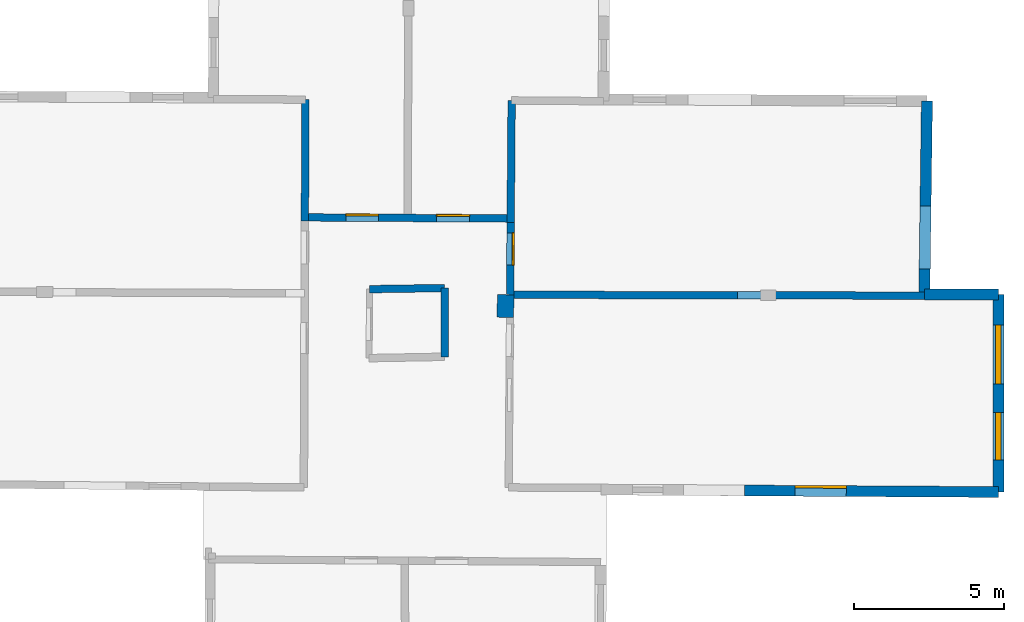
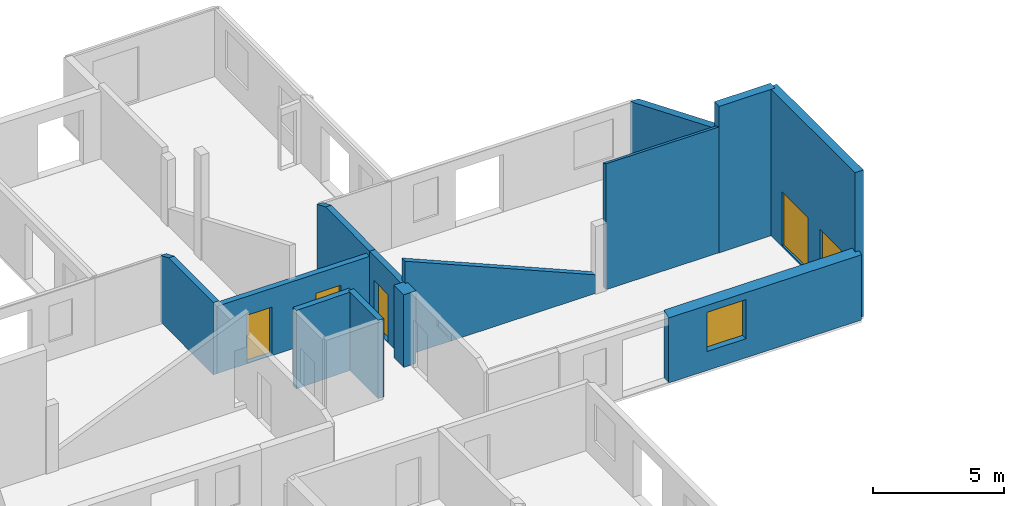
# One storey, part 7 of 10: 13 walls, 4 doors, 2 windows, 7 openings.
"""IFC2X3 building model written with IfcOpenShell, lengths in metres."""

from ifc_helpers import new_model, entity, si_unit, converted_unit, derived_unit, direction, frame, frame_2d, origin, origin_2d_with_axis, place, context, subcontext, project, spatial, polyline, rectangle, outline, extrude, clip, halfspace, source, transform, mapped, material, layer, layer_set, layer_usage, type_object, type_shapes, element, fill, save


model = new_model("IFC2X3")

# Units and contexts
model_context = context("Model", 3, precision=1e-05, world=origin(), true_north=direction((0.0, 1.0)))
body_context = subcontext(model_context, "Body", "Model", "MODEL_VIEW")
ifc_project = project(units=[si_unit("LENGTHUNIT", "METRE"), si_unit("AREAUNIT", "SQUARE_METRE"), si_unit("VOLUMEUNIT", "CUBIC_METRE"), converted_unit("PLANEANGLEUNIT", "DEGREE", entity("IfcRatioMeasure", 0.0174532925199433), si_unit("PLANEANGLEUNIT", "RADIAN"), dimensions=[0, 0, 0, 0, 0, 0, 0]), si_unit("MASSUNIT", "GRAM", prefix="KILO"), derived_unit("MASSDENSITYUNIT", [(si_unit("MASSUNIT", "GRAM", prefix="KILO"), 1), (si_unit("LENGTHUNIT", "METRE"), -3)]), derived_unit("MOMENTOFINERTIAUNIT", [(si_unit("LENGTHUNIT", "METRE"), 4)]), si_unit("TIMEUNIT", "SECOND"), si_unit("FREQUENCYUNIT", "HERTZ"), si_unit("THERMODYNAMICTEMPERATUREUNIT", "DEGREE_CELSIUS"), derived_unit("THERMALTRANSMITTANCEUNIT", [(si_unit("MASSUNIT", "GRAM", prefix="KILO"), 1), (si_unit("THERMODYNAMICTEMPERATUREUNIT", "KELVIN"), -1), (si_unit("TIMEUNIT", "SECOND"), -3)]), derived_unit("VOLUMETRICFLOWRATEUNIT", [(si_unit("LENGTHUNIT", "METRE"), 3), (si_unit("TIMEUNIT", "SECOND"), -1)]), si_unit("ELECTRICCURRENTUNIT", "AMPERE"), si_unit("ELECTRICVOLTAGEUNIT", "VOLT"), si_unit("POWERUNIT", "WATT"), si_unit("FORCEUNIT", "NEWTON", prefix="KILO"), si_unit("ILLUMINANCEUNIT", "LUX"), si_unit("LUMINOUSFLUXUNIT", "LUMEN"), si_unit("LUMINOUSINTENSITYUNIT", "CANDELA"), derived_unit("USERDEFINED", [(si_unit("MASSUNIT", "GRAM", prefix="KILO"), -1), (si_unit("LENGTHUNIT", "METRE"), -2), (si_unit("TIMEUNIT", "SECOND"), 3), (si_unit("LUMINOUSFLUXUNIT", "LUMEN"), 1)]), derived_unit("LINEARVELOCITYUNIT", [(si_unit("LENGTHUNIT", "METRE"), 1), (si_unit("TIMEUNIT", "SECOND"), -1)]), si_unit("PRESSUREUNIT", "PASCAL"), derived_unit("USERDEFINED", [(si_unit("LENGTHUNIT", "METRE"), -2), (si_unit("MASSUNIT", "GRAM", prefix="KILO"), 1), (si_unit("TIMEUNIT", "SECOND"), -2)]), derived_unit("LINEARFORCEUNIT", [(si_unit("MASSUNIT", "GRAM", prefix="KILO"), 1), (si_unit("LENGTHUNIT", "METRE"), 1), (si_unit("TIMEUNIT", "SECOND"), -2), (si_unit("LENGTHUNIT", "METRE"), -1)]), derived_unit("PLANARFORCEUNIT", [(si_unit("MASSUNIT", "GRAM", prefix="KILO"), 1), (si_unit("LENGTHUNIT", "METRE"), 1), (si_unit("TIMEUNIT", "SECOND"), -2), (si_unit("LENGTHUNIT", "METRE"), -2)])], contexts=[model_context])

# Site, building, storey
placement = place(None, origin())
site = spatial("IfcSite", under=ifc_project, at=placement, CompositionType="ELEMENT")
building = spatial("IfcBuilding", under=site, at=placement, CompositionType="ELEMENT")
storey_placement = place(placement, frame((0.0, 0.0, 15.2695512771606)))
storey = spatial("IfcBuildingStorey", under=building, at=storey_placement, Name="Level 6", CompositionType="ELEMENT", Elevation=15.2695512771606)

# Wall, openings, doors
ifc_material_1 = material(Name="Default wall")
ifc_layer_1 = layer(ifc_material_1, 0.25)
ifc_layer_set_1 = layer_set([ifc_layer_1], Name="wall_thickness_0.2500")
ifc_layer_usage_1 = layer_usage(ifc_layer_set_1, "AXIS2", "POSITIVE", -0.125)
wall_type_1 = type_object("IfcWallType", Name="wall_thickness_0.2500", PredefinedType="STANDARD", material=ifc_layer_set_1)
wall_1_placement = place(storey_placement, frame((2.96713424520515, 60.1743794273045, 0.0), z_axis=(0.0, 0.0, 1.0), x_axis=(0.999985370043432, -0.00540922352097356, 0.0)))
wall_1 = element("IfcWallStandardCase", 1, at=wall_1_placement, inside=storey, type_object=wall_type_1, material=ifc_layer_usage_1, Name="Wall:130", ObjectType="Wall", context=body_context, shape_type="Clipping", body=[
    clip(clip(extrude(outline(polyline([(6.8448736711646, -0.125), (6.8448736711646, 0.125), (0.0, 0.125), (0.0, -0.125), (6.8448736711646, -0.125)])), origin(), (0.0, 0.0, 1.0), 3.13044834136963), halfspace(frame((21.6737388787584, -2.55460759701524, 5.8221630359936), z_axis=(0.000366542898802136, 0.389455013607563, 0.921045415830423), x_axis=(-0.999995954296972, 0.00274085757237607, -0.000760979274747706)), False)), halfspace(frame((9.75695270182333, 17.1152665483417, 3.16730048752112), z_axis=(0.390500067069403, 0.000208506375133906, 0.920602875372374), x_axis=(-0.680068275737413, -0.67394641392533, 0.288623234499112)), False)),
])
opening_1_placement = place(wall_1_placement, frame((1.36070263379295, -0.125, 0.0334491729736328)))
opening_1 = element("IfcOpeningElement", 2, at=opening_1_placement, cuts=wall_1, Name="Opening : 1085 x 2225 : 119", ObjectType="Opening", context=body_context, shape_type="SweptSolid", body=[
    extrude(rectangle(XDim=1.085, YDim=2.225, at=frame_2d((1.1125, 0.5425), x_axis=(0.0, 1.0))), frame((0.0, 0.0, 0.0), z_axis=(0.0, 1.0, 0.0), x_axis=(0.0, 0.0, 1.0)), (0.0, 0.0, 1.0), 0.25),
])
opening_2_placement = place(wall_1_placement, frame((4.37401757615406, -0.125, 0.00844955444335938)))
opening_2 = element("IfcOpeningElement", 3, at=opening_2_placement, cuts=wall_1, Name="Opening : 1105 x 2220 : 120", ObjectType="Opening", context=body_context, shape_type="SweptSolid", body=[
    extrude(rectangle(XDim=1.105, YDim=2.22, at=frame_2d((1.11, 0.5525), x_axis=(0.0, 1.0))), frame((0.0, 0.0, 0.0), z_axis=(0.0, 1.0, 0.0), x_axis=(0.0, 0.0, 1.0)), (0.0, 0.0, 1.0), 0.25),
])
ifc_material_2 = material(Name="Door Panel")
door_style_1 = type_object("IfcDoorStyle", Name="Door : 1085 x 2225mm", ConstructionType="NOTDEFINED", OperationType="SINGLE_SWING_RIGHT", ParameterTakesPrecedence=False, Sizeable=False, material=ifc_material_2)
shared_shape_1 = source(origin(), body_context, "Body", "SweptSolid", [
    extrude(rectangle(XDim=0.0625, YDim=1.085, at=origin_2d_with_axis()), frame((0.5425, 0.21875, 0.0), z_axis=(0.0, 0.0, 1.0), x_axis=(0.0, 1.0, 0.0)), (0.0, 0.0, 1.0), 2.225),
])
type_shapes(door_style_1, [shared_shape_1])
door_1_placement = place(opening_1_placement, origin())
door_1 = element("IfcDoor", 4, at=door_1_placement, inside=storey, type_object=door_style_1, Name="Door : 1085 x 2225mm : 18", ObjectType="Door : 1085 x 2225mm", OverallHeight=2.225, OverallWidth=1.085, context=body_context, shape_type="MappedRepresentation", body=[
    mapped(shared_shape_1, transform((0.0, 0.0, 0.0), scale=1.0)),
])
fill(opening_1, door_1)
door_style_2 = type_object("IfcDoorStyle", Name="Door : 1105 x 2220mm", ConstructionType="NOTDEFINED", OperationType="SINGLE_SWING_RIGHT", ParameterTakesPrecedence=False, Sizeable=False, material=ifc_material_2)
shared_shape_2 = source(origin(), body_context, "Body", "SweptSolid", [
    extrude(rectangle(XDim=0.0625, YDim=1.105, at=origin_2d_with_axis()), frame((0.5525, 0.21875, 0.0), z_axis=(0.0, 0.0, 1.0), x_axis=(0.0, 1.0, 0.0)), (0.0, 0.0, 1.0), 2.22),
])
type_shapes(door_style_2, [shared_shape_2])
door_2_placement = place(opening_2_placement, origin())
door_2 = element("IfcDoor", 5, at=door_2_placement, inside=storey, type_object=door_style_2, Name="Door : 1105 x 2220mm : 19", ObjectType="Door : 1105 x 2220mm", OverallHeight=2.22, OverallWidth=1.105, context=body_context, shape_type="MappedRepresentation", body=[
    mapped(shared_shape_2, transform((0.0, 0.0, 0.0), scale=1.0)),
])
fill(opening_2, door_2)

# Walls
wall_2_placement = place(storey_placement, frame((7.61093044283214, 57.8249602665871, 0.0), z_axis=(0.0, 0.0, 1.0), x_axis=(1.87735608155193e-05, -0.999999999823777, 0.0)))
element("IfcWallStandardCase", 6, at=wall_2_placement, inside=storey, type_object=wall_type_1, material=ifc_layer_usage_1, Name="Wall:150", ObjectType="Wall", context=body_context, shape_type="Clipping", body=[
    clip(clip(extrude(outline(polyline([(2.28594589273682, -0.125), (2.28594589273682, 0.125), (0.0, 0.125), (0.0, -0.125), (2.28594589273682, -0.125)])), origin(), (0.0, 0.0, 1.0), 3.64244747161865), halfspace(frame((0.0173498715267402, -20.3641007855674, 5.82614615592769), z_axis=(0.391110357303732, -0.00389535867308116, 0.920335544565435), x_axis=(0.00816873617874139, 0.999966345768865, 0.00076097234127326)), False)), halfspace(frame((-19.4115600444475, 5.20595848780353, 3.16730048752112), z_axis=(0.00191112981338156, 0.390495446118074, 0.920602875372374), x_axis=(0.670245077131597, -0.68371643616936, 0.288623234499112)), False)),
])
wall_3_placement = place(storey_placement, frame((18.6168514417804, 57.5909596654291, 0.0), z_axis=(0.0, 0.0, 1.0), x_axis=(0.999985671317579, -0.0053532382284126, 0.0)))
element("IfcWallStandardCase", 7, at=wall_3_placement, inside=storey, type_object=wall_type_1, material=ifc_layer_usage_1, Name="Wall:160", ObjectType="Wall", context=body_context, shape_type="Clipping", body=[
    clip(extrude(outline(polyline([(4.95254365019272, -0.125), (4.95254365019272, 0.125), (0.0, 0.125), (0.0, -0.125), (4.95254365019272, -0.125)])), origin(), (0.0, 0.0, 1.0), 6.0254487991333), halfspace(frame((6.01027320408955, -0.0562149406787543, 5.8221630359936), z_axis=(0.000388346966794823, 0.389454992475892, 0.921045415830423), x_axis=(-0.999995799279822, 0.00279684344473516, -0.000760979274747706)), False)),
])
wall_4_placement = place(storey_placement, frame((9.79176478291498, 57.6015514875423, 0.0), z_axis=(0.0, 0.0, 1.0), x_axis=(0.999996547055359, -0.00262790360528779, 0.0)))
element("IfcWallStandardCase", 8, at=wall_4_placement, inside=storey, type_object=wall_type_1, material=ifc_layer_usage_1, Name="Wall:165", ObjectType="Wall", context=body_context, shape_type="Clipping", body=[
    clip(clip(extrude(outline(polyline([(8.35402893755218, -0.125), (8.35402893755218, 0.125), (0.0, 0.125), (0.0, -0.125), (8.35402893755218, -0.125)])), origin(), (0.0, 0.0, 1.0), 4.78644847869873), halfspace(frame((14.8351816982513, -0.0599951612753503, 5.8221630359936), z_axis=(0.00144974816553861, 0.38945248774147, 0.921045415830423), x_axis=(-0.999984463123986, 0.00552217540250109, -0.000760979274747706)), False)), halfspace(frame((2.97315021618388, 19.6429475326324, 3.16730048752112), z_axis=(0.39049913656848, -0.000877607764519829, 0.920602875372374), x_axis=(-0.681940119185066, -0.672052306262785, 0.288623234499112)), False)),
])
wall_5_placement = place(storey_placement, frame((9.84309972223119, 64.0643778277319, 0.0), z_axis=(0.0, 0.0, 1.0), x_axis=(-0.00794283618112411, -0.999968455179162, 0.0)))
element("IfcWallStandardCase", 9, at=wall_5_placement, inside=storey, type_object=wall_type_1, material=ifc_layer_usage_1, Name="Wall:195", ObjectType="Wall", context=body_context, shape_type="Clipping", body=[
    clip(clip(extrude(outline(polyline([(4.05214885092084, -0.125), (4.05214885092084, 0.125), (0.0, 0.125), (0.0, -0.125), (4.05214885092084, -0.125)])), origin(), (0.0, 0.0, 1.0), 3.37544918060303), halfspace(frame((6.44417571697616, 14.8352908810085, 5.8221630359936), z_axis=(-0.389454692256058, -0.00062020762863599, 0.921045415830423), x_axis=(-0.000207191935612451, -0.999999688990974, -0.000760979274747706)), False)), halfspace(frame((-13.195442124254, 2.8687060410717, 3.16730048752112), z_axis=(-0.00119790287437693, 0.390498285380129, 0.920602875372374), x_axis=(0.675667317341875, -0.678358537046085, 0.288623234499112)), False)),
])

# Wall, opening, door
wall_6_placement = place(storey_placement, frame((9.81091416772679, 60.0123568011206, 0.0), z_axis=(0.0, 0.0, 1.0), x_axis=(-0.0079422728057511, -0.999968459653943, 0.0)))
wall_6 = element("IfcWallStandardCase", 10, at=wall_6_placement, inside=storey, type_object=wall_type_1, material=ifc_layer_usage_1, Name="Wall:196", ObjectType="Wall", context=body_context, shape_type="Clipping", body=[
    clip(clip(extrude(outline(polyline([(2.41088078854953, -0.125), (2.41088078854953, 0.125), (0.0, 0.125), (0.0, -0.125), (2.41088078854953, -0.125)])), origin(), (0.0, 0.0, 1.0), 3.37544918060303), halfspace(frame((2.39203522415612, 14.8352895333547, 5.8221630359936), z_axis=(-0.389454692605417, -0.000619988212532408, 0.921045415830423), x_axis=(-0.000207755328581094, -0.999999688874085, -0.000760979274747706)), False)), halfspace(frame((-17.2475893589628, 2.86871575824574, 3.16730048752112), z_axis=(-0.00119768287032005, 0.390498286054957, 0.920602875372374), x_axis=(0.675666935159218, -0.678358917712312, 0.288623234499112)), False)),
])
opening_3_placement = place(wall_6_placement, frame((0.35481241104698, -0.125, 0.00944900512695312)))
opening_3 = element("IfcOpeningElement", 11, at=opening_3_placement, cuts=wall_6, Name="Opening : 1070 x 2220 : 175", ObjectType="Opening", context=body_context, shape_type="SweptSolid", body=[
    extrude(rectangle(XDim=1.07, YDim=2.22, at=frame_2d((1.11, 0.535), x_axis=(0.0, 1.0))), frame((0.0, 0.0, 0.0), z_axis=(0.0, 1.0, 0.0), x_axis=(0.0, 0.0, 1.0)), (0.0, 0.0, 1.0), 0.25),
])
door_style_3 = type_object("IfcDoorStyle", Name="Door : 1070 x 2220mm", ConstructionType="NOTDEFINED", OperationType="SINGLE_SWING_RIGHT", ParameterTakesPrecedence=False, Sizeable=False, material=ifc_material_2)
shared_shape_3 = source(origin(), body_context, "Body", "SweptSolid", [
    extrude(rectangle(XDim=0.0625, YDim=1.07, at=origin_2d_with_axis()), frame((0.535, 0.21875, 0.0), z_axis=(0.0, 0.0, 1.0), x_axis=(0.0, 1.0, 0.0)), (0.0, 0.0, 1.0), 2.22),
])
type_shapes(door_style_3, [shared_shape_3])
door_3_placement = place(opening_3_placement, origin())
door_3 = element("IfcDoor", 12, at=door_3_placement, inside=storey, type_object=door_style_3, Name="Door : 1070 x 2220mm : 28", ObjectType="Door : 1070 x 2220mm", OverallHeight=2.22, OverallWidth=1.07, context=body_context, shape_type="MappedRepresentation", body=[
    mapped(shared_shape_3, transform((0.0, 0.0, 0.0), scale=1.0)),
])
fill(opening_3, door_3)

# Walls
wall_7_placement = place(storey_placement, frame((5.11043810102694, 57.7871503661398, 0.0), z_axis=(0.0, 0.0, 1.0), x_axis=(0.999885689276901, 0.015119800900034, 0.0)))
element("IfcWallStandardCase", 13, at=wall_7_placement, inside=storey, type_object=wall_type_1, material=ifc_layer_usage_1, Name="Wall:205", ObjectType="Wall", context=body_context, shape_type="Clipping", body=[
    clip(clip(extrude(outline(polyline([(2.50077891546772, -0.125), (2.50077891546772, 0.125), (0.0, 0.125), (0.0, -0.125), (2.50077891546772, -0.125)])), origin(), (0.0, 0.0, 1.0), 3.64244747161865), halfspace(frame((19.509765789516, -0.57962929237007, 5.8221630359936), z_axis=(0.00836127018330491, 0.38936542108755, 0.921045415830423), x_axis=(-0.999728964928544, 0.0232683818398806, -0.000760979274747706)), False)), halfspace(frame((7.99927759514966, 19.3307299009827, 3.16730048752112), z_axis=(0.390422059047907, -0.00780779513753255, 0.920602875372374), x_axis=(-0.693759864673609, -0.659843829004505, 0.288623234499112)), False)),
])
wall_8_placement = place(storey_placement, frame((2.98214551114995, 64.0932674848867, 0.0), z_axis=(0.0, 0.0, 1.0), x_axis=(-0.00383033958072565, -0.999992664222441, 0.0)))
element("IfcWallStandardCase", 14, at=wall_8_placement, inside=storey, type_object=wall_type_1, material=ifc_layer_usage_1, Name="Wall:208", ObjectType="Wall", context=body_context, shape_type="Clipping", body=[
    clip(clip(extrude(outline(polyline([(4.04391775732215, -0.125), (4.04391775732215, 0.125), (0.0, 0.125), (0.0, -0.125), (4.04391775732215, -0.125)])), origin(), (0.0, 0.0, 1.0), 3.35544872283936), halfspace(frame((6.50774189328117, 21.6696779087464, 5.8221630359936), z_axis=(-0.389453949431275, 0.000981453078607484, 0.921045415830423), x_axis=(-0.00431974806532357, -0.999990380297328, -0.000760979274747706)), False)), halfspace(frame((-11.7341901356349, -4.28992372672169, 2.60439273833051), z_axis=(7.90232870469798e-05, -0.389900765766629, 0.920856876289642), x_axis=(0.00201983010084243, 0.920853798789848, 0.389902810378011)), False)),
])

# Wall, opening
ifc_layer_2 = layer(ifc_material_1, 0.370000004768372)
ifc_layer_set_2 = layer_set([ifc_layer_2], Name="wall_thickness_0.3700")
ifc_layer_usage_2 = layer_usage(ifc_layer_set_2, "AXIS2", "POSITIVE", -0.185000002384186)
wall_type_2 = type_object("IfcWallType", Name="wall_thickness_0.3700", PredefinedType="STANDARD", material=ifc_layer_set_2)
wall_9_placement = place(storey_placement, frame((23.6571476457567, 64.0447204201303, 0.0), z_axis=(0.0, 0.0, 1.0), x_axis=(-0.0135515503501826, -0.999908173525503, 0.0)))
wall_9 = element("IfcWallStandardCase", 15, at=wall_9_placement, inside=storey, type_object=wall_type_2, material=ifc_layer_usage_2, Name="Wall:148", ObjectType="Wall", context=body_context, shape_type="Clipping", body=[
    clip(extrude(outline(polyline([(6.48086550077282, -0.185000002384186), (6.48086550077282, 0.185000002384186), (0.0, 0.185000002384186), (0.0, -0.185000002384186), (6.48086550077282, -0.185000002384186)])), origin(), (0.0, 0.0, 1.0), 5.75544834136963), halfspace(frame((6.52840912465529, 1.05815718065052, 5.8221630359936), z_axis=(-0.389445087124403, -0.00280465549216105, 0.921045415830423), x_axis=(0.00540182562967213, -0.999985120484505, -0.000760979274747706)), False)),
])
opening_4_placement = place(wall_9_placement, frame((3.49483149957379, -0.185000002384186, 0.00544929504394531)))
element("IfcOpeningElement", 16, at=opening_4_placement, cuts=wall_9, Name="Opening : 2090 x 2635 : 143", ObjectType="Opening", context=body_context, shape_type="SweptSolid", body=[
    extrude(rectangle(XDim=2.09, YDim=2.635, at=frame_2d((1.3175, 1.045), x_axis=(0.0, 1.0))), frame((0.0, 0.0, 0.0), z_axis=(0.0, 1.0, 0.0), x_axis=(0.0, 0.0, 1.0)), (0.0, 0.0, 1.0), 0.370000004768372),
])

# Wall
wall_10_placement = place(storey_placement, frame((23.5700194670916, 57.6154303237509, 0.0), z_axis=(0.0, 0.0, 1.0), x_axis=(0.999999846957537, -0.000553249403728531, 0.0)))
element("IfcWallStandardCase", 17, at=wall_10_placement, inside=storey, type_object=wall_type_2, material=ifc_layer_usage_2, Name="Wall:162", ObjectType="Wall", context=body_context, shape_type="SweptSolid", body=[
    extrude(outline(polyline([(2.46154250623713, -0.185000002384186), (2.46154250623713, 0.185000002384186), (0.0, 0.185000002384186), (0.0, -0.185000002384186), (2.46154250623713, -0.185000002384186)])), origin(), (0.0, 0.0, 1.0), 6.8064489364624),
])

# Wall, openings, windows
wall_11_placement = place(storey_placement, frame((26.031562287599, 57.6140712689486, 0.0), z_axis=(0.0, 0.0, 1.0), x_axis=(0.000451476916185785, -0.999999898084292, 0.0)))
wall_11 = element("IfcWallStandardCase", 18, at=wall_11_placement, inside=storey, type_object=wall_type_2, material=ifc_layer_usage_2, Name="Wall:189", ObjectType="Wall", context=body_context, shape_type="SweptSolid", body=[
    extrude(outline(polyline([(6.57361288308918, -0.185000002384186), (6.57361288308918, 0.185000002384186), (0.0, 0.185000002384186), (0.0, -0.185000002384186), (6.57361288308918, -0.185000002384186)])), origin(), (0.0, 0.0, 1.0), 6.8064489364624),
])
opening_5_placement = place(wall_11_placement, frame((3.92166175290253, -0.185000002384186, 0.855448722839355)))
opening_5 = element("IfcOpeningElement", 19, at=opening_5_placement, cuts=wall_11, Name="Opening : 1585 x 1710 : 168", ObjectType="Opening", context=body_context, shape_type="SweptSolid", body=[
    extrude(rectangle(XDim=1.585, YDim=1.71, at=frame_2d((0.855, 0.7925), x_axis=(0.0, 1.0))), frame((0.0, 0.0, 0.0), z_axis=(0.0, 1.0, 0.0), x_axis=(0.0, 0.0, 1.0)), (0.0, 0.0, 1.0), 0.370000004768372),
])
opening_6_placement = place(wall_11_placement, frame((1.01666267807856, -0.185000002384186, 0.0604486465454102)))
opening_6 = element("IfcOpeningElement", 20, at=opening_6_placement, cuts=wall_11, Name="Opening : 1970 x 2485 : 169", ObjectType="Opening", context=body_context, shape_type="SweptSolid", body=[
    extrude(rectangle(XDim=1.97, YDim=2.485, at=frame_2d((1.2425, 0.985), x_axis=(0.0, 1.0))), frame((0.0, 0.0, 0.0), z_axis=(0.0, 1.0, 0.0), x_axis=(0.0, 0.0, 1.0)), (0.0, 0.0, 1.0), 0.370000004768372),
])
ifc_material_3 = material(Name="Window Default")
window_style_1 = type_object("IfcWindowStyle", Name="Window : 1585 x 1710mm", ConstructionType="NOTDEFINED", OperationType="NOTDEFINED", ParameterTakesPrecedence=False, Sizeable=False, material=ifc_material_3)
shared_shape_4 = source(origin(), body_context, "Body", "SweptSolid", [
    extrude(rectangle(XDim=0.185000002384186, YDim=1.585, at=origin_2d_with_axis()), frame((0.7925, 0.185000002384186, 0.0), z_axis=(0.0, 0.0, 1.0), x_axis=(0.0, 1.0, 0.0)), (0.0, 0.0, 1.0), 1.71),
])
type_shapes(window_style_1, [shared_shape_4])
window_1_placement = place(opening_5_placement, origin())
window_1 = element("IfcWindow", 21, at=window_1_placement, inside=storey, type_object=window_style_1, Name="Window : 1585 x 1710mm : 92", ObjectType="Window : 1585 x 1710mm", OverallHeight=1.71, OverallWidth=1.585, context=body_context, shape_type="MappedRepresentation", body=[
    mapped(shared_shape_4, transform((0.0, 0.0, 0.0), scale=1.0)),
])
fill(opening_5, window_1)
window_style_2 = type_object("IfcWindowStyle", Name="Window : 1970 x 2485mm", ConstructionType="NOTDEFINED", OperationType="NOTDEFINED", ParameterTakesPrecedence=False, Sizeable=False, material=ifc_material_3)
shared_shape_5 = source(origin(), body_context, "Body", "SweptSolid", [
    extrude(rectangle(XDim=0.185000002384186, YDim=1.97, at=origin_2d_with_axis()), frame((0.985, 0.185000002384186, 0.0), z_axis=(0.0, 0.0, 1.0), x_axis=(0.0, 1.0, 0.0)), (0.0, 0.0, 1.0), 2.485),
])
type_shapes(window_style_2, [shared_shape_5])
window_2_placement = place(opening_6_placement, origin())
window_2 = element("IfcWindow", 22, at=window_2_placement, inside=storey, type_object=window_style_2, Name="Window : 1970 x 2485mm : 93", ObjectType="Window : 1970 x 2485mm", OverallHeight=2.485, OverallWidth=1.97, context=body_context, shape_type="MappedRepresentation", body=[
    mapped(shared_shape_5, transform((0.0, 0.0, 0.0), scale=1.0)),
])
fill(opening_6, window_2)

# Wall, opening, door
ifc_layer_3 = layer(ifc_material_1, 0.360000014305115)
ifc_layer_set_3 = layer_set([ifc_layer_3], Name="wall_thickness_0.3600")
ifc_layer_usage_3 = layer_usage(ifc_layer_set_3, "AXIS2", "POSITIVE", -0.180000007152557)
wall_type_3 = type_object("IfcWallType", Name="wall_thickness_0.3600", PredefinedType="STANDARD", material=ifc_layer_set_3)
wall_12_placement = place(storey_placement, frame((17.5844501203115, 51.0916940863254, 0.0), z_axis=(0.0, 0.0, 1.0), x_axis=(0.999981621566873, -0.00606271626311458, 0.0)))
wall_12 = element("IfcWallStandardCase", 23, at=wall_12_placement, inside=storey, type_object=wall_type_3, material=ifc_layer_usage_3, Name="Wall:127", ObjectType="Wall", context=body_context, shape_type="Clipping", body=[
    clip(extrude(outline(polyline([(8.45023617368246, -0.180000007152557), (8.45023617368246, 0.180000007152557), (0.0, 0.180000007152557), (0.0, -0.180000007152557), (8.45023617368246, -0.180000007152557)])), origin(), (0.0, 0.0, 1.0), 5.08544826507568), halfspace(frame((-30.3777769530261, 6.53148219809191, 5.82614615592769), z_axis=(-0.00151675311582671, -0.391126814306345, 0.920335544565435), x_axis=(0.999997532046212, -0.00208730030899422, 0.000760972341273259)), False)),
])
opening_7_placement = place(wall_12_placement, frame((1.68866393798081, -0.180000007152557, 0.885449409484863)))
opening_7 = element("IfcOpeningElement", 24, at=opening_7_placement, cuts=wall_12, Name="Opening : 1700 x 1820 : 117", ObjectType="Opening", context=body_context, shape_type="SweptSolid", body=[
    extrude(rectangle(XDim=1.7, YDim=1.82, at=frame_2d((0.91, 0.85), x_axis=(0.0, 1.0))), frame((0.0, 0.0, 0.0), z_axis=(0.0, 1.0, 0.0), x_axis=(0.0, 0.0, 1.0)), (0.0, 0.0, 1.0), 0.360000014305115),
])
door_style_4 = type_object("IfcDoorStyle", Name="Door : 1700 x 1820mm", ConstructionType="NOTDEFINED", OperationType="SINGLE_SWING_RIGHT", ParameterTakesPrecedence=False, Sizeable=False, material=ifc_material_2)
shared_shape_6 = source(origin(), body_context, "Body", "SweptSolid", [
    extrude(rectangle(XDim=0.0900000035762787, YDim=1.7, at=origin_2d_with_axis()), frame((0.85, 0.315000012516975, 0.0), z_axis=(0.0, 0.0, 1.0), x_axis=(0.0, 1.0, 0.0)), (0.0, 0.0, 1.0), 1.82),
])
type_shapes(door_style_4, [shared_shape_6])
door_4_placement = place(opening_7_placement, origin())
door_4 = element("IfcDoor", 25, at=door_4_placement, inside=storey, type_object=door_style_4, Name="Door : 1700 x 1820mm : 17", ObjectType="Door : 1700 x 1820mm", OverallHeight=1.82, OverallWidth=1.7, context=body_context, shape_type="MappedRepresentation", body=[
    mapped(shared_shape_6, transform((0.0, 0.0, 0.0), scale=1.0)),
])
fill(opening_7, door_4)

# Wall
ifc_layer_4 = layer(ifc_material_1, 0.550000011920929)
ifc_layer_set_4 = layer_set([ifc_layer_4], Name="wall_thickness_0.5500")
ifc_layer_usage_4 = layer_usage(ifc_layer_set_4, "AXIS2", "POSITIVE", -0.275000005960464)
wall_type_4 = type_object("IfcWallType", Name="wall_thickness_0.5500", PredefinedType="STANDARD", material=ifc_layer_set_4)
wall_13_placement = place(storey_placement, frame((9.64176339076695, 57.6019385261547, 0.0), z_axis=(0.0, 0.0, 1.0), x_axis=(-0.00794255314102542, -0.999968457427334, 0.0)))
element("IfcWallStandardCase", 26, at=wall_13_placement, inside=storey, type_object=wall_type_4, material=ifc_layer_usage_4, Name="Wall:197", ObjectType="Wall", context=body_context, shape_type="Clipping", body=[
    clip(clip(extrude(outline(polyline([(0.750206768920273, -0.275000005960464), (0.750206768920273, 0.275000005960464), (0.0, 0.275000005960464), (0.0, -0.275000005960464), (0.750206768920273, -0.275000005960464)])), origin(), (0.0, 0.0, 1.0), 3.37544918060303), halfspace(frame((-0.0274101382107382, -22.3958575336377, 5.82614615592769), z_axis=(0.391128974510183, -0.000781478123104816, 0.920335544565435), x_axis=(0.000207419120341099, 0.999999688949154, 0.000760972341273259)), False)), halfspace(frame((-19.6592758963968, 3.01871148925358, 3.16730048752112), z_axis=(-0.00119779234421712, 0.390498285719179, 0.920602875372374), x_axis=(0.675667125333123, -0.678358728293035, 0.288623234499112)), False)),
])

save(model, "model.ifc")
